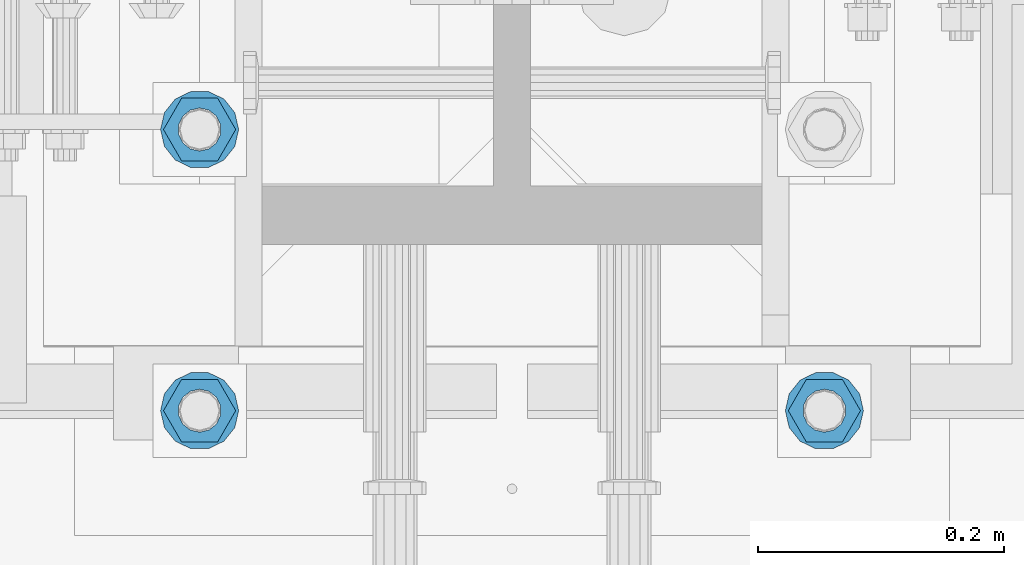
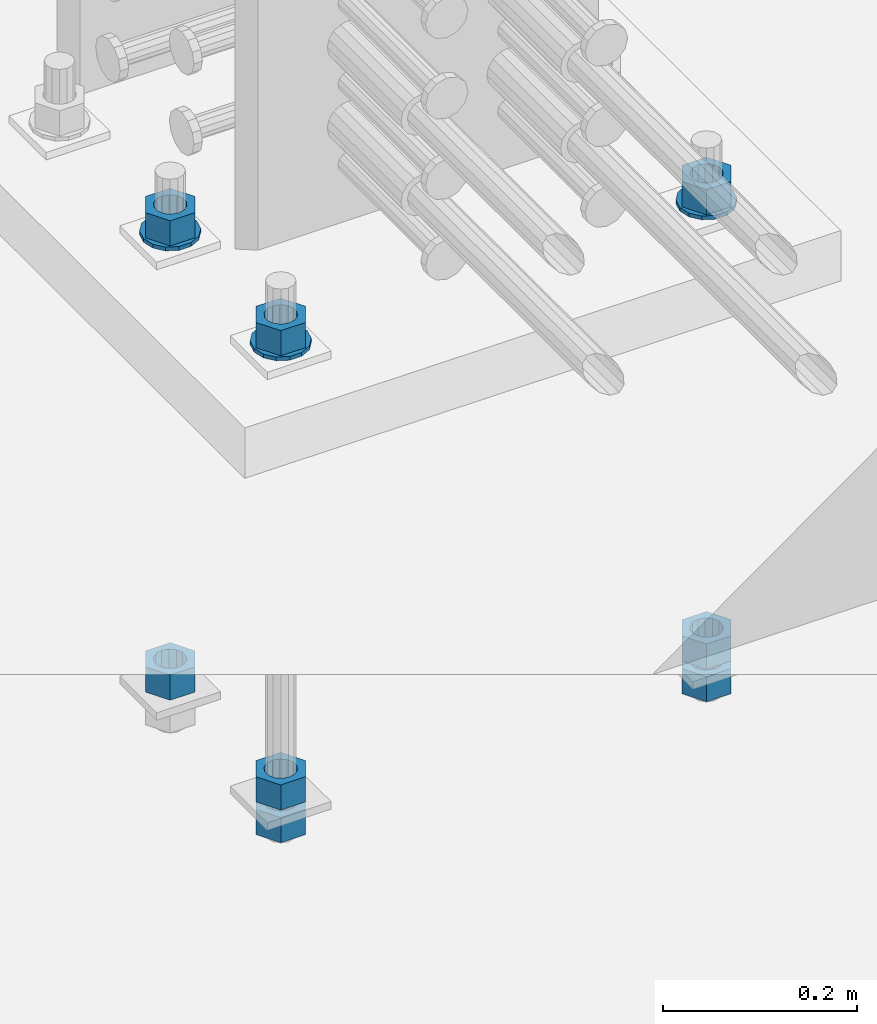
# One storey, part 1007 of 1763: 11 columns, 1 element without a shape of its own.
"""IFC2X3 building model written with IfcOpenShell, lengths in millimetres."""

from ifc_helpers import new_model, si_unit, frame, origin_with_axes, place, context, subcontext, project, spatial, faceted_brep, material, type_object, element, aggregate, save


model = new_model("IFC2X3")

# Units and contexts
model_context = context("Model", 3, precision=1e-05, world=origin_with_axes())
body_context = subcontext(model_context, "Body", "Model", "MODEL_VIEW")
ifc_project = project(units=[si_unit("LENGTHUNIT", "METRE", prefix="MILLI"), si_unit("AREAUNIT", "SQUARE_METRE"), si_unit("VOLUMEUNIT", "CUBIC_METRE"), si_unit("MASSUNIT", "GRAM", prefix="KILO"), si_unit("TIMEUNIT", "SECOND"), si_unit("PLANEANGLEUNIT", "RADIAN"), si_unit("SOLIDANGLEUNIT", "STERADIAN"), si_unit("THERMODYNAMICTEMPERATUREUNIT", "DEGREE_CELSIUS"), si_unit("LUMINOUSINTENSITYUNIT", "LUMEN")], contexts=[model_context])

# Site, building, storey
site_placement = place(None, origin_with_axes())
site = spatial("IfcSite", under=ifc_project, at=site_placement, CompositionType="ELEMENT")
building_placement = place(site_placement, origin_with_axes())
building = spatial("IfcBuilding", under=site, at=building_placement, Name="Undefined", CompositionType="ELEMENT")
storey_placement = place(building_placement, origin_with_axes())
storey = spatial("IfcBuildingStorey", under=building, at=storey_placement, Name="Undefined", CompositionType="ELEMENT", Elevation=0.0)

# Assembly, columns
assembly_placement = place(storey_placement, origin_with_axes())
assembly = element("IfcElementAssembly", 1, at=assembly_placement, inside=storey, Name="TEMPLATE", AssemblyPlace="NOTDEFINED", PredefinedType="RIGID_FRAME")
ifc_material_1 = material(Name="STEEL/A563")
column_type_1 = type_object("IfcColumnType", Name="1-1/4_HEAVY_HEX_NUT", PredefinedType="NOTDEFINED")
column_1_placement = place(assembly_placement, frame((-24281.8372736984, -14058.9000000001, 3957.6375), z_axis=(0.0, -1.0, 0.0), x_axis=(0.0, 0.0, -1.0)))
column_1 = element("IfcColumn", 2, at=column_1_placement, type_object=column_type_1, material=ifc_material_1, Name="NUT", ObjectType="1-1/4_HEAVY_HEX_NUT", context=body_context, shape_type="Brep", body=[
    faceted_brep([(0.0, -29.3700008392334, 0.0), (0.0, -14.6800003051758, -25.4300003051758), (31.75, -14.6800003051758, -25.4300003051758), (31.75, -29.3700008392334, 0.0), (0.0, 14.6800003051758, -25.4300003051758), (31.75, 14.6800003051758, -25.4300003051758), (0.0, 29.3700008392334, 0.0), (31.75, 29.3700008392334, 0.0), (0.0, 14.6800003051758, 25.4300003051758), (31.75, 14.6800003051758, 25.4300003051758), (0.0, -14.6800003051758, 25.4300003051758), (31.75, -14.6800003051758, 25.4300003051758), (0.0, 0.0, 17.4599990844727), (0.0, 7.57560968776022, 15.730915608714), (31.75, 7.57560968775942, 15.7309156087145), (31.75, 0.0, 17.4599990844727), (0.0, 13.6507769681037, 10.8861313696252), (31.75, 13.6507769681048, 10.8861313696314), (0.0, 17.0222404541215, 3.88521530314756), (31.75, 17.02224045412, 3.88521530315316), (0.0, 17.0222404541215, -3.88521530314756), (31.75, 17.02224045412, -3.88521530315332), (0.0, 13.6507769681037, -10.8861313696252), (31.75, 13.6507769681048, -10.8861313696316), (0.0, 7.57560968776022, -15.730915608714), (31.75, 7.57560968775942, -15.7309156087146), (0.0, 0.0, -17.4599990844727), (31.75, 0.0, -17.4599990844727), (0.0, -7.57560968776022, -15.730915608714), (31.75, -7.57560968775942, -15.7309156087145), (0.0, -13.6507769681037, -10.8861313696252), (31.75, -13.6507769681048, -10.8861313696314), (0.0, -17.0222404541215, -3.88521530314756), (31.75, -17.02224045412, -3.88521530315316), (0.0, -17.0222404541215, 3.88521530314756), (31.75, -17.02224045412, 3.88521530315332), (0.0, -13.6507769681037, 10.8861313696252), (31.75, -13.6507769681048, 10.8861313696316), (0.0, -7.57560968776022, 15.730915608714), (31.75, -7.57560968775942, 15.7309156087146)], [[[0, 1, 2, 3]], [[1, 4, 5, 2]], [[4, 6, 7, 5]], [[6, 8, 9, 7]], [[8, 10, 11, 9]], [[10, 0, 3, 11]], [[12, 13, 14, 15]], [[13, 16, 17, 14]], [[16, 18, 19, 17]], [[18, 20, 21, 19]], [[20, 22, 23, 21]], [[22, 24, 25, 23]], [[24, 26, 27, 25]], [[26, 28, 29, 27]], [[28, 30, 31, 29]], [[30, 32, 33, 31]], [[32, 34, 35, 33]], [[34, 36, 37, 35]], [[36, 38, 39, 37]], [[38, 12, 15, 39]], [[5, 7, 9, 11, 3, 2], [17, 19, 21, 23, 25, 27, 29, 31, 33, 35, 37, 39, 15, 14]], [[10, 8, 6, 4, 1, 0], [38, 36, 34, 32, 30, 28, 26, 24, 22, 20, 18, 16, 13, 12]]]),
])
column_2_placement = place(assembly_placement, frame((-24281.8372736984, -14058.9000000001, 3384.55), z_axis=(0.0, -1.0, 0.0), x_axis=(0.0, 0.0, -1.0)))
column_2 = element("IfcColumn", 3, at=column_2_placement, type_object=column_type_1, material=ifc_material_1, Name="NUT", ObjectType="1-1/4_HEAVY_HEX_NUT", context=body_context, shape_type="Brep", body=[
    faceted_brep([(0.0, -29.3700008392334, 0.0), (0.0, -14.6800003051758, -25.4300003051758), (31.75, -14.6800003051758, -25.4300003051758), (31.75, -29.3700008392334, 0.0), (0.0, 14.6800003051758, -25.4300003051758), (31.75, 14.6800003051758, -25.4300003051758), (0.0, 29.3700008392334, 0.0), (31.75, 29.3700008392334, 0.0), (0.0, 14.6800003051758, 25.4300003051758), (31.75, 14.6800003051758, 25.4300003051758), (0.0, -14.6800003051758, 25.4300003051758), (31.75, -14.6800003051758, 25.4300003051758), (0.0, 0.0, 17.4599990844727), (0.0, 7.57560968776022, 15.730915608714), (31.75, 7.57560968775942, 15.7309156087145), (31.75, 0.0, 17.4599990844727), (0.0, 13.6507769681037, 10.8861313696252), (31.75, 13.6507769681048, 10.8861313696314), (0.0, 17.0222404541215, 3.88521530314756), (31.75, 17.02224045412, 3.88521530315316), (0.0, 17.0222404541215, -3.88521530314756), (31.75, 17.02224045412, -3.88521530315332), (0.0, 13.6507769681037, -10.8861313696252), (31.75, 13.6507769681048, -10.8861313696316), (0.0, 7.57560968776022, -15.730915608714), (31.75, 7.57560968775942, -15.7309156087146), (0.0, 0.0, -17.4599990844727), (31.75, 0.0, -17.4599990844727), (0.0, -7.57560968776022, -15.730915608714), (31.75, -7.57560968775942, -15.7309156087145), (0.0, -13.6507769681037, -10.8861313696252), (31.75, -13.6507769681048, -10.8861313696314), (0.0, -17.0222404541215, -3.88521530314756), (31.75, -17.02224045412, -3.88521530315316), (0.0, -17.0222404541215, 3.88521530314756), (31.75, -17.02224045412, 3.88521530315332), (0.0, -13.6507769681037, 10.8861313696252), (31.75, -13.6507769681048, 10.8861313696316), (0.0, -7.57560968776022, 15.730915608714), (31.75, -7.57560968775942, 15.7309156087146)], [[[0, 1, 2, 3]], [[1, 4, 5, 2]], [[4, 6, 7, 5]], [[6, 8, 9, 7]], [[8, 10, 11, 9]], [[10, 0, 3, 11]], [[12, 13, 14, 15]], [[13, 16, 17, 14]], [[16, 18, 19, 17]], [[18, 20, 21, 19]], [[20, 22, 23, 21]], [[22, 24, 25, 23]], [[24, 26, 27, 25]], [[26, 28, 29, 27]], [[28, 30, 31, 29]], [[30, 32, 33, 31]], [[32, 34, 35, 33]], [[34, 36, 37, 35]], [[36, 38, 39, 37]], [[38, 12, 15, 39]], [[5, 7, 9, 11, 3, 2], [17, 19, 21, 23, 25, 27, 29, 31, 33, 35, 37, 39, 15, 14]], [[10, 8, 6, 4, 1, 0], [38, 36, 34, 32, 30, 28, 26, 24, 22, 20, 18, 16, 13, 12]]]),
])
column_3_placement = place(assembly_placement, frame((-24281.8372736984, -14058.9000000001, 3343.275), z_axis=(0.0, -1.0, 0.0), x_axis=(0.0, 0.0, -1.0)))
column_3 = element("IfcColumn", 4, at=column_3_placement, type_object=column_type_1, material=ifc_material_1, Name="NUT", ObjectType="1-1/4_HEAVY_HEX_NUT", context=body_context, shape_type="Brep", body=[
    faceted_brep([(0.0, -29.3700008392334, 0.0), (0.0, -14.6800003051758, -25.4300003051758), (31.75, -14.6800003051758, -25.4300003051758), (31.75, -29.3700008392334, 0.0), (0.0, 14.6800003051758, -25.4300003051758), (31.75, 14.6800003051758, -25.4300003051758), (0.0, 29.3700008392334, 0.0), (31.75, 29.3700008392334, 0.0), (0.0, 14.6800003051758, 25.4300003051758), (31.75, 14.6800003051758, 25.4300003051758), (0.0, -14.6800003051758, 25.4300003051758), (31.75, -14.6800003051758, 25.4300003051758), (0.0, 0.0, 17.4599990844727), (0.0, 7.57560968776022, 15.730915608714), (31.75, 7.57560968775942, 15.7309156087145), (31.75, 0.0, 17.4599990844727), (0.0, 13.6507769681037, 10.8861313696252), (31.75, 13.6507769681048, 10.8861313696314), (0.0, 17.0222404541215, 3.88521530314756), (31.75, 17.02224045412, 3.88521530315316), (0.0, 17.0222404541215, -3.88521530314756), (31.75, 17.02224045412, -3.88521530315332), (0.0, 13.6507769681037, -10.8861313696252), (31.75, 13.6507769681048, -10.8861313696316), (0.0, 7.57560968776022, -15.730915608714), (31.75, 7.57560968775942, -15.7309156087146), (0.0, 0.0, -17.4599990844727), (31.75, 0.0, -17.4599990844727), (0.0, -7.57560968776022, -15.730915608714), (31.75, -7.57560968775942, -15.7309156087145), (0.0, -13.6507769681037, -10.8861313696252), (31.75, -13.6507769681048, -10.8861313696314), (0.0, -17.0222404541215, -3.88521530314756), (31.75, -17.02224045412, -3.88521530315316), (0.0, -17.0222404541215, 3.88521530314756), (31.75, -17.02224045412, 3.88521530315332), (0.0, -13.6507769681037, 10.8861313696252), (31.75, -13.6507769681048, 10.8861313696316), (0.0, -7.57560968776022, 15.730915608714), (31.75, -7.57560968775942, 15.7309156087146)], [[[0, 1, 2, 3]], [[1, 4, 5, 2]], [[4, 6, 7, 5]], [[6, 8, 9, 7]], [[8, 10, 11, 9]], [[10, 0, 3, 11]], [[12, 13, 14, 15]], [[13, 16, 17, 14]], [[16, 18, 19, 17]], [[18, 20, 21, 19]], [[20, 22, 23, 21]], [[22, 24, 25, 23]], [[24, 26, 27, 25]], [[26, 28, 29, 27]], [[28, 30, 31, 29]], [[30, 32, 33, 31]], [[32, 34, 35, 33]], [[34, 36, 37, 35]], [[36, 38, 39, 37]], [[38, 12, 15, 39]], [[5, 7, 9, 11, 3, 2], [17, 19, 21, 23, 25, 27, 29, 31, 33, 35, 37, 39, 15, 14]], [[10, 8, 6, 4, 1, 0], [38, 36, 34, 32, 30, 28, 26, 24, 22, 20, 18, 16, 13, 12]]]),
])
column_4_placement = place(assembly_placement, frame((-23773.8372736984, -14058.9000000001, 3957.6375), z_axis=(0.0, 1.0, 0.0), x_axis=(0.0, 0.0, -1.0)))
column_4 = element("IfcColumn", 5, at=column_4_placement, type_object=column_type_1, material=ifc_material_1, Name="NUT", ObjectType="1-1/4_HEAVY_HEX_NUT", context=body_context, shape_type="Brep", body=[
    faceted_brep([(0.0, -29.3700008392334, 0.0), (0.0, -14.6800003051758, -25.4300003051758), (31.75, -14.6800003051758, -25.4300003051758), (31.75, -29.3700008392334, 0.0), (0.0, 14.6800003051758, -25.4300003051758), (31.75, 14.6800003051758, -25.4300003051758), (0.0, 29.3700008392334, 0.0), (31.75, 29.3700008392334, 0.0), (0.0, 14.6800003051758, 25.4300003051758), (31.75, 14.6800003051758, 25.4300003051758), (0.0, -14.6800003051758, 25.4300003051758), (31.75, -14.6800003051758, 25.4300003051758), (0.0, 0.0, 17.4599990844727), (0.0, 7.57560968776022, 15.730915608714), (31.75, 7.57560968775942, 15.7309156087145), (31.75, 0.0, 17.4599990844727), (0.0, 13.6507769681037, 10.8861313696252), (31.75, 13.6507769681048, 10.8861313696314), (0.0, 17.0222404541215, 3.88521530314756), (31.75, 17.02224045412, 3.88521530315316), (0.0, 17.0222404541215, -3.88521530314756), (31.75, 17.02224045412, -3.88521530315332), (0.0, 13.6507769681037, -10.8861313696252), (31.75, 13.6507769681048, -10.8861313696316), (0.0, 7.57560968776022, -15.730915608714), (31.75, 7.57560968775942, -15.7309156087146), (0.0, 0.0, -17.4599990844727), (31.75, 0.0, -17.4599990844727), (0.0, -7.57560968776022, -15.730915608714), (31.75, -7.57560968775942, -15.7309156087145), (0.0, -13.6507769681037, -10.8861313696252), (31.75, -13.6507769681048, -10.8861313696314), (0.0, -17.0222404541215, -3.88521530314756), (31.75, -17.02224045412, -3.88521530315316), (0.0, -17.0222404541215, 3.88521530314756), (31.75, -17.02224045412, 3.88521530315332), (0.0, -13.6507769681037, 10.8861313696252), (31.75, -13.6507769681048, 10.8861313696316), (0.0, -7.57560968776022, 15.730915608714), (31.75, -7.57560968775942, 15.7309156087146)], [[[0, 1, 2, 3]], [[1, 4, 5, 2]], [[4, 6, 7, 5]], [[6, 8, 9, 7]], [[8, 10, 11, 9]], [[10, 0, 3, 11]], [[12, 13, 14, 15]], [[13, 16, 17, 14]], [[16, 18, 19, 17]], [[18, 20, 21, 19]], [[20, 22, 23, 21]], [[22, 24, 25, 23]], [[24, 26, 27, 25]], [[26, 28, 29, 27]], [[28, 30, 31, 29]], [[30, 32, 33, 31]], [[32, 34, 35, 33]], [[34, 36, 37, 35]], [[36, 38, 39, 37]], [[38, 12, 15, 39]], [[5, 7, 9, 11, 3, 2], [17, 19, 21, 23, 25, 27, 29, 31, 33, 35, 37, 39, 15, 14]], [[10, 8, 6, 4, 1, 0], [38, 36, 34, 32, 30, 28, 26, 24, 22, 20, 18, 16, 13, 12]]]),
])
column_5_placement = place(assembly_placement, frame((-23773.8372736984, -14058.9000000001, 3384.55), z_axis=(0.0, 1.0, 0.0), x_axis=(0.0, 0.0, -1.0)))
column_5 = element("IfcColumn", 6, at=column_5_placement, type_object=column_type_1, material=ifc_material_1, Name="NUT", ObjectType="1-1/4_HEAVY_HEX_NUT", context=body_context, shape_type="Brep", body=[
    faceted_brep([(0.0, -29.3700008392334, 0.0), (0.0, -14.6800003051758, -25.4300003051758), (31.75, -14.6800003051758, -25.4300003051758), (31.75, -29.3700008392334, 0.0), (0.0, 14.6800003051758, -25.4300003051758), (31.75, 14.6800003051758, -25.4300003051758), (0.0, 29.3700008392334, 0.0), (31.75, 29.3700008392334, 0.0), (0.0, 14.6800003051758, 25.4300003051758), (31.75, 14.6800003051758, 25.4300003051758), (0.0, -14.6800003051758, 25.4300003051758), (31.75, -14.6800003051758, 25.4300003051758), (0.0, 0.0, 17.4599990844727), (0.0, 7.57560968776022, 15.730915608714), (31.75, 7.57560968775942, 15.7309156087145), (31.75, 0.0, 17.4599990844727), (0.0, 13.6507769681037, 10.8861313696252), (31.75, 13.6507769681048, 10.8861313696314), (0.0, 17.0222404541215, 3.88521530314756), (31.75, 17.02224045412, 3.88521530315316), (0.0, 17.0222404541215, -3.88521530314756), (31.75, 17.02224045412, -3.88521530315332), (0.0, 13.6507769681037, -10.8861313696252), (31.75, 13.6507769681048, -10.8861313696316), (0.0, 7.57560968776022, -15.730915608714), (31.75, 7.57560968775942, -15.7309156087146), (0.0, 0.0, -17.4599990844727), (31.75, 0.0, -17.4599990844727), (0.0, -7.57560968776022, -15.730915608714), (31.75, -7.57560968775942, -15.7309156087145), (0.0, -13.6507769681037, -10.8861313696252), (31.75, -13.6507769681048, -10.8861313696314), (0.0, -17.0222404541215, -3.88521530314756), (31.75, -17.02224045412, -3.88521530315316), (0.0, -17.0222404541215, 3.88521530314756), (31.75, -17.02224045412, 3.88521530315332), (0.0, -13.6507769681037, 10.8861313696252), (31.75, -13.6507769681048, 10.8861313696316), (0.0, -7.57560968776022, 15.730915608714), (31.75, -7.57560968775942, 15.7309156087146)], [[[0, 1, 2, 3]], [[1, 4, 5, 2]], [[4, 6, 7, 5]], [[6, 8, 9, 7]], [[8, 10, 11, 9]], [[10, 0, 3, 11]], [[12, 13, 14, 15]], [[13, 16, 17, 14]], [[16, 18, 19, 17]], [[18, 20, 21, 19]], [[20, 22, 23, 21]], [[22, 24, 25, 23]], [[24, 26, 27, 25]], [[26, 28, 29, 27]], [[28, 30, 31, 29]], [[30, 32, 33, 31]], [[32, 34, 35, 33]], [[34, 36, 37, 35]], [[36, 38, 39, 37]], [[38, 12, 15, 39]], [[5, 7, 9, 11, 3, 2], [17, 19, 21, 23, 25, 27, 29, 31, 33, 35, 37, 39, 15, 14]], [[10, 8, 6, 4, 1, 0], [38, 36, 34, 32, 30, 28, 26, 24, 22, 20, 18, 16, 13, 12]]]),
])
column_6_placement = place(assembly_placement, frame((-23773.8372736984, -14058.9000000001, 3343.275), z_axis=(0.0, 1.0, 0.0), x_axis=(0.0, 0.0, -1.0)))
column_6 = element("IfcColumn", 7, at=column_6_placement, type_object=column_type_1, material=ifc_material_1, Name="NUT", ObjectType="1-1/4_HEAVY_HEX_NUT", context=body_context, shape_type="Brep", body=[
    faceted_brep([(0.0, -29.3700008392334, 0.0), (0.0, -14.6800003051758, -25.4300003051758), (31.75, -14.6800003051758, -25.4300003051758), (31.75, -29.3700008392334, 0.0), (0.0, 14.6800003051758, -25.4300003051758), (31.75, 14.6800003051758, -25.4300003051758), (0.0, 29.3700008392334, 0.0), (31.75, 29.3700008392334, 0.0), (0.0, 14.6800003051758, 25.4300003051758), (31.75, 14.6800003051758, 25.4300003051758), (0.0, -14.6800003051758, 25.4300003051758), (31.75, -14.6800003051758, 25.4300003051758), (0.0, 0.0, 17.4599990844727), (0.0, 7.57560968776022, 15.730915608714), (31.75, 7.57560968775942, 15.7309156087145), (31.75, 0.0, 17.4599990844727), (0.0, 13.6507769681037, 10.8861313696252), (31.75, 13.6507769681048, 10.8861313696314), (0.0, 17.0222404541215, 3.88521530314756), (31.75, 17.02224045412, 3.88521530315316), (0.0, 17.0222404541215, -3.88521530314756), (31.75, 17.02224045412, -3.88521530315332), (0.0, 13.6507769681037, -10.8861313696252), (31.75, 13.6507769681048, -10.8861313696316), (0.0, 7.57560968776022, -15.730915608714), (31.75, 7.57560968775942, -15.7309156087146), (0.0, 0.0, -17.4599990844727), (31.75, 0.0, -17.4599990844727), (0.0, -7.57560968776022, -15.730915608714), (31.75, -7.57560968775942, -15.7309156087145), (0.0, -13.6507769681037, -10.8861313696252), (31.75, -13.6507769681048, -10.8861313696314), (0.0, -17.0222404541215, -3.88521530314756), (31.75, -17.02224045412, -3.88521530315316), (0.0, -17.0222404541215, 3.88521530314756), (31.75, -17.02224045412, 3.88521530315332), (0.0, -13.6507769681037, 10.8861313696252), (31.75, -13.6507769681048, 10.8861313696316), (0.0, -7.57560968776022, 15.730915608714), (31.75, -7.57560968775942, 15.7309156087146)], [[[0, 1, 2, 3]], [[1, 4, 5, 2]], [[4, 6, 7, 5]], [[6, 8, 9, 7]], [[8, 10, 11, 9]], [[10, 0, 3, 11]], [[12, 13, 14, 15]], [[13, 16, 17, 14]], [[16, 18, 19, 17]], [[18, 20, 21, 19]], [[20, 22, 23, 21]], [[22, 24, 25, 23]], [[24, 26, 27, 25]], [[26, 28, 29, 27]], [[28, 30, 31, 29]], [[30, 32, 33, 31]], [[32, 34, 35, 33]], [[34, 36, 37, 35]], [[36, 38, 39, 37]], [[38, 12, 15, 39]], [[5, 7, 9, 11, 3, 2], [17, 19, 21, 23, 25, 27, 29, 31, 33, 35, 37, 39, 15, 14]], [[10, 8, 6, 4, 1, 0], [38, 36, 34, 32, 30, 28, 26, 24, 22, 20, 18, 16, 13, 12]]]),
])
column_7_placement = place(assembly_placement, frame((-24281.8372736984, -13830.3000000001, 3957.6375), z_axis=(0.0, -1.0, 0.0), x_axis=(0.0, 0.0, -1.0)))
column_7 = element("IfcColumn", 8, at=column_7_placement, type_object=column_type_1, material=ifc_material_1, Name="NUT", ObjectType="1-1/4_HEAVY_HEX_NUT", context=body_context, shape_type="Brep", body=[
    faceted_brep([(0.0, -29.3700008392334, 0.0), (0.0, -14.6800003051758, -25.4300003051758), (31.75, -14.6800003051758, -25.4300003051758), (31.75, -29.3700008392334, 0.0), (0.0, 14.6800003051758, -25.4300003051758), (31.75, 14.6800003051758, -25.4300003051758), (0.0, 29.3700008392334, 0.0), (31.75, 29.3700008392334, 0.0), (0.0, 14.6800003051758, 25.4300003051758), (31.75, 14.6800003051758, 25.4300003051758), (0.0, -14.6800003051758, 25.4300003051758), (31.75, -14.6800003051758, 25.4300003051758), (0.0, 0.0, 17.4599990844727), (0.0, 7.57560968776022, 15.730915608714), (31.75, 7.57560968775942, 15.7309156087145), (31.75, 0.0, 17.4599990844727), (0.0, 13.6507769681037, 10.8861313696252), (31.75, 13.6507769681048, 10.8861313696314), (0.0, 17.0222404541215, 3.88521530314756), (31.75, 17.02224045412, 3.88521530315316), (0.0, 17.0222404541215, -3.88521530314756), (31.75, 17.02224045412, -3.88521530315332), (0.0, 13.6507769681037, -10.8861313696252), (31.75, 13.6507769681048, -10.8861313696316), (0.0, 7.57560968776022, -15.730915608714), (31.75, 7.57560968775942, -15.7309156087146), (0.0, 0.0, -17.4599990844727), (31.75, 0.0, -17.4599990844727), (0.0, -7.57560968776022, -15.730915608714), (31.75, -7.57560968775942, -15.7309156087145), (0.0, -13.6507769681037, -10.8861313696252), (31.75, -13.6507769681048, -10.8861313696314), (0.0, -17.0222404541215, -3.88521530314756), (31.75, -17.02224045412, -3.88521530315316), (0.0, -17.0222404541215, 3.88521530314756), (31.75, -17.02224045412, 3.88521530315332), (0.0, -13.6507769681037, 10.8861313696252), (31.75, -13.6507769681048, 10.8861313696316), (0.0, -7.57560968776022, 15.730915608714), (31.75, -7.57560968775942, 15.7309156087146)], [[[0, 1, 2, 3]], [[1, 4, 5, 2]], [[4, 6, 7, 5]], [[6, 8, 9, 7]], [[8, 10, 11, 9]], [[10, 0, 3, 11]], [[12, 13, 14, 15]], [[13, 16, 17, 14]], [[16, 18, 19, 17]], [[18, 20, 21, 19]], [[20, 22, 23, 21]], [[22, 24, 25, 23]], [[24, 26, 27, 25]], [[26, 28, 29, 27]], [[28, 30, 31, 29]], [[30, 32, 33, 31]], [[32, 34, 35, 33]], [[34, 36, 37, 35]], [[36, 38, 39, 37]], [[38, 12, 15, 39]], [[5, 7, 9, 11, 3, 2], [17, 19, 21, 23, 25, 27, 29, 31, 33, 35, 37, 39, 15, 14]], [[10, 8, 6, 4, 1, 0], [38, 36, 34, 32, 30, 28, 26, 24, 22, 20, 18, 16, 13, 12]]]),
])
column_8_placement = place(assembly_placement, frame((-24281.8372736984, -13830.3000000001, 3384.55), z_axis=(0.0, -1.0, 0.0), x_axis=(0.0, 0.0, -1.0)))
column_8 = element("IfcColumn", 9, at=column_8_placement, type_object=column_type_1, material=ifc_material_1, Name="NUT", ObjectType="1-1/4_HEAVY_HEX_NUT", context=body_context, shape_type="Brep", body=[
    faceted_brep([(0.0, -29.3700008392334, 0.0), (0.0, -14.6800003051758, -25.4300003051758), (31.75, -14.6800003051758, -25.4300003051758), (31.75, -29.3700008392334, 0.0), (0.0, 14.6800003051758, -25.4300003051758), (31.75, 14.6800003051758, -25.4300003051758), (0.0, 29.3700008392334, 0.0), (31.75, 29.3700008392334, 0.0), (0.0, 14.6800003051758, 25.4300003051758), (31.75, 14.6800003051758, 25.4300003051758), (0.0, -14.6800003051758, 25.4300003051758), (31.75, -14.6800003051758, 25.4300003051758), (0.0, 0.0, 17.4599990844727), (0.0, 7.57560968776022, 15.730915608714), (31.75, 7.57560968775942, 15.7309156087145), (31.75, 0.0, 17.4599990844727), (0.0, 13.6507769681037, 10.8861313696252), (31.75, 13.6507769681048, 10.8861313696314), (0.0, 17.0222404541215, 3.88521530314756), (31.75, 17.02224045412, 3.88521530315316), (0.0, 17.0222404541215, -3.88521530314756), (31.75, 17.02224045412, -3.88521530315332), (0.0, 13.6507769681037, -10.8861313696252), (31.75, 13.6507769681048, -10.8861313696316), (0.0, 7.57560968776022, -15.730915608714), (31.75, 7.57560968775942, -15.7309156087146), (0.0, 0.0, -17.4599990844727), (31.75, 0.0, -17.4599990844727), (0.0, -7.57560968776022, -15.730915608714), (31.75, -7.57560968775942, -15.7309156087145), (0.0, -13.6507769681037, -10.8861313696252), (31.75, -13.6507769681048, -10.8861313696314), (0.0, -17.0222404541215, -3.88521530314756), (31.75, -17.02224045412, -3.88521530315316), (0.0, -17.0222404541215, 3.88521530314756), (31.75, -17.02224045412, 3.88521530315332), (0.0, -13.6507769681037, 10.8861313696252), (31.75, -13.6507769681048, 10.8861313696316), (0.0, -7.57560968776022, 15.730915608714), (31.75, -7.57560968775942, 15.7309156087146)], [[[0, 1, 2, 3]], [[1, 4, 5, 2]], [[4, 6, 7, 5]], [[6, 8, 9, 7]], [[8, 10, 11, 9]], [[10, 0, 3, 11]], [[12, 13, 14, 15]], [[13, 16, 17, 14]], [[16, 18, 19, 17]], [[18, 20, 21, 19]], [[20, 22, 23, 21]], [[22, 24, 25, 23]], [[24, 26, 27, 25]], [[26, 28, 29, 27]], [[28, 30, 31, 29]], [[30, 32, 33, 31]], [[32, 34, 35, 33]], [[34, 36, 37, 35]], [[36, 38, 39, 37]], [[38, 12, 15, 39]], [[5, 7, 9, 11, 3, 2], [17, 19, 21, 23, 25, 27, 29, 31, 33, 35, 37, 39, 15, 14]], [[10, 8, 6, 4, 1, 0], [38, 36, 34, 32, 30, 28, 26, 24, 22, 20, 18, 16, 13, 12]]]),
])
ifc_material_2 = material(Name="STEEL/F436")
column_type_2 = type_object("IfcColumnType", Name="1-1/4_WASHER", PredefinedType="NOTDEFINED")
column_9_placement = place(assembly_placement, frame((-24281.8372736984, -14058.9000000001, 3925.8875), z_axis=(0.0, -1.0, 0.0), x_axis=(0.0, 0.0, -1.0)))
column_9 = element("IfcColumn", 10, at=column_9_placement, type_object=column_type_2, material=ifc_material_2, Name="WASHER", ObjectType="1-1/4_WASHER", context=body_context, shape_type="Brep", body=[
    faceted_brep([(-4.54747350886464e-13, -31.7499999999964, 0.0), (0.0, -28.6057615559002, -13.7758087169827), (4.76249999999982, -28.6057615559002, -13.7758087169827), (4.76249999999982, -31.75, 0.0), (0.0, -19.795801209013, -24.8231495683602), (4.76249999999982, -19.795801209013, -24.8231495683602), (0.0, -7.06503965311276, -30.9539612117732), (4.76249999999982, -7.06503965311276, -30.9539612117732), (0.0, 7.06503965311276, -30.9539612117732), (4.76249999999982, 7.06503965311276, -30.9539612117732), (0.0, 19.7958012090166, -24.8231495683602), (4.76249999999982, 19.7958012090166, -24.8231495683602), (0.0, 28.6057615559039, -13.7758087169827), (4.76249999999982, 28.6057615559039, -13.7758087169827), (-5.91171556152403e-12, 31.7499999999891, 0.0), (4.76249999999982, 31.75, 0.0), (0.0, 28.6057615559002, 13.7758087169827), (4.76249999999982, 28.6057615559002, 13.7758087169827), (0.0, 19.795801209013, 24.8231495683602), (4.76249999999982, 19.795801209013, 24.8231495683602), (0.0, 7.06503965311276, 30.9539612117731), (4.76249999999982, 7.06503965311276, 30.9539612117731), (0.0, -7.06503965311276, 30.9539612117731), (4.76249999999982, -7.06503965311276, 30.9539612117731), (0.0, -19.7958012090166, 24.8231495683602), (4.76249999999982, -19.7958012090166, 24.8231495683602), (0.0, -28.6057615559039, 13.7758087169827), (4.76249999999982, -28.6057615559039, 13.7758087169827), (0.0, 0.0, 17.4599990844727), (0.0, 7.57560968776022, 15.730915608714), (4.76249999999982, 7.57560968775942, 15.7309156087145), (4.76249999999982, 0.0, 17.4599990844727), (0.0, 13.6507769681037, 10.8861313696252), (4.76249999999982, 13.6507769681048, 10.8861313696314), (0.0, 17.0222404541215, 3.88521530314756), (4.76249999999982, 17.02224045412, 3.88521530315316), (0.0, 17.0222404541215, -3.88521530314756), (4.76249999999982, 17.02224045412, -3.88521530315332), (0.0, 13.6507769681037, -10.8861313696252), (4.76249999999982, 13.6507769681048, -10.8861313696316), (0.0, 7.57560968776022, -15.730915608714), (4.76249999999982, 7.57560968775942, -15.7309156087146), (0.0, 0.0, -17.4599990844727), (4.76249999999982, 0.0, -17.4599990844727), (0.0, -7.57560968776022, -15.730915608714), (4.76249999999982, -7.57560968775942, -15.7309156087145), (0.0, -13.6507769681037, -10.8861313696252), (4.76249999999982, -13.6507769681048, -10.8861313696314), (0.0, -17.0222404541215, -3.88521530314756), (4.76249999999982, -17.02224045412, -3.88521530315316), (0.0, -17.0222404541215, 3.88521530314756), (4.76249999999982, -17.02224045412, 3.88521530315332), (0.0, -13.6507769681037, 10.8861313696252), (4.76249999999982, -13.6507769681048, 10.8861313696316), (0.0, -7.57560968776022, 15.730915608714), (4.76249999999982, -7.57560968775942, 15.7309156087146)], [[[0, 1, 2, 3]], [[1, 4, 5, 2]], [[4, 6, 7, 5]], [[6, 8, 9, 7]], [[8, 10, 11, 9]], [[10, 12, 13, 11]], [[12, 14, 15, 13]], [[14, 16, 17, 15]], [[16, 18, 19, 17]], [[18, 20, 21, 19]], [[20, 22, 23, 21]], [[22, 24, 25, 23]], [[24, 26, 27, 25]], [[26, 0, 3, 27]], [[28, 29, 30, 31]], [[29, 32, 33, 30]], [[32, 34, 35, 33]], [[34, 36, 37, 35]], [[36, 38, 39, 37]], [[38, 40, 41, 39]], [[40, 42, 43, 41]], [[42, 44, 45, 43]], [[44, 46, 47, 45]], [[46, 48, 49, 47]], [[48, 50, 51, 49]], [[50, 52, 53, 51]], [[52, 54, 55, 53]], [[54, 28, 31, 55]], [[5, 7, 9, 11, 13, 15, 17, 19, 21, 23, 25, 27, 3, 2], [33, 35, 37, 39, 41, 43, 45, 47, 49, 51, 53, 55, 31, 30]], [[26, 24, 22, 20, 18, 16, 14, 12, 10, 8, 6, 4, 1, 0], [54, 52, 50, 48, 46, 44, 42, 40, 38, 36, 34, 32, 29, 28]]]),
])
column_10_placement = place(assembly_placement, frame((-23773.8372736984, -14058.9000000001, 3925.8875), z_axis=(0.0, 1.0, 0.0), x_axis=(0.0, 0.0, -1.0)))
column_10 = element("IfcColumn", 11, at=column_10_placement, type_object=column_type_2, material=ifc_material_2, Name="WASHER", ObjectType="1-1/4_WASHER", context=body_context, shape_type="Brep", body=[
    faceted_brep([(-4.54747350886464e-13, -31.7499999999964, 0.0), (0.0, -28.6057615559002, -13.7758087169827), (4.76249999999982, -28.6057615559002, -13.7758087169827), (4.76249999999982, -31.75, 0.0), (0.0, -19.795801209013, -24.8231495683602), (4.76249999999982, -19.795801209013, -24.8231495683602), (0.0, -7.06503965311276, -30.9539612117732), (4.76249999999982, -7.06503965311276, -30.9539612117732), (0.0, 7.06503965311276, -30.9539612117732), (4.76249999999982, 7.06503965311276, -30.9539612117732), (0.0, 19.7958012090166, -24.8231495683602), (4.76249999999982, 19.7958012090166, -24.8231495683602), (0.0, 28.6057615559039, -13.7758087169827), (4.76249999999982, 28.6057615559039, -13.7758087169827), (-5.91171556152403e-12, 31.7499999999891, 0.0), (4.76249999999982, 31.75, 0.0), (0.0, 28.6057615559002, 13.7758087169827), (4.76249999999982, 28.6057615559002, 13.7758087169827), (0.0, 19.795801209013, 24.8231495683602), (4.76249999999982, 19.795801209013, 24.8231495683602), (0.0, 7.06503965311276, 30.9539612117731), (4.76249999999982, 7.06503965311276, 30.9539612117731), (0.0, -7.06503965311276, 30.9539612117731), (4.76249999999982, -7.06503965311276, 30.9539612117731), (0.0, -19.7958012090166, 24.8231495683602), (4.76249999999982, -19.7958012090166, 24.8231495683602), (0.0, -28.6057615559039, 13.7758087169827), (4.76249999999982, -28.6057615559039, 13.7758087169827), (0.0, 0.0, 17.4599990844727), (0.0, 7.57560968776022, 15.730915608714), (4.76249999999982, 7.57560968775942, 15.7309156087145), (4.76249999999982, 0.0, 17.4599990844727), (0.0, 13.6507769681037, 10.8861313696252), (4.76249999999982, 13.6507769681048, 10.8861313696314), (0.0, 17.0222404541215, 3.88521530314756), (4.76249999999982, 17.02224045412, 3.88521530315316), (0.0, 17.0222404541215, -3.88521530314756), (4.76249999999982, 17.02224045412, -3.88521530315332), (0.0, 13.6507769681037, -10.8861313696252), (4.76249999999982, 13.6507769681048, -10.8861313696316), (0.0, 7.57560968776022, -15.730915608714), (4.76249999999982, 7.57560968775942, -15.7309156087146), (0.0, 0.0, -17.4599990844727), (4.76249999999982, 0.0, -17.4599990844727), (0.0, -7.57560968776022, -15.730915608714), (4.76249999999982, -7.57560968775942, -15.7309156087145), (0.0, -13.6507769681037, -10.8861313696252), (4.76249999999982, -13.6507769681048, -10.8861313696314), (0.0, -17.0222404541215, -3.88521530314756), (4.76249999999982, -17.02224045412, -3.88521530315316), (0.0, -17.0222404541215, 3.88521530314756), (4.76249999999982, -17.02224045412, 3.88521530315332), (0.0, -13.6507769681037, 10.8861313696252), (4.76249999999982, -13.6507769681048, 10.8861313696316), (0.0, -7.57560968776022, 15.730915608714), (4.76249999999982, -7.57560968775942, 15.7309156087146)], [[[0, 1, 2, 3]], [[1, 4, 5, 2]], [[4, 6, 7, 5]], [[6, 8, 9, 7]], [[8, 10, 11, 9]], [[10, 12, 13, 11]], [[12, 14, 15, 13]], [[14, 16, 17, 15]], [[16, 18, 19, 17]], [[18, 20, 21, 19]], [[20, 22, 23, 21]], [[22, 24, 25, 23]], [[24, 26, 27, 25]], [[26, 0, 3, 27]], [[28, 29, 30, 31]], [[29, 32, 33, 30]], [[32, 34, 35, 33]], [[34, 36, 37, 35]], [[36, 38, 39, 37]], [[38, 40, 41, 39]], [[40, 42, 43, 41]], [[42, 44, 45, 43]], [[44, 46, 47, 45]], [[46, 48, 49, 47]], [[48, 50, 51, 49]], [[50, 52, 53, 51]], [[52, 54, 55, 53]], [[54, 28, 31, 55]], [[5, 7, 9, 11, 13, 15, 17, 19, 21, 23, 25, 27, 3, 2], [33, 35, 37, 39, 41, 43, 45, 47, 49, 51, 53, 55, 31, 30]], [[26, 24, 22, 20, 18, 16, 14, 12, 10, 8, 6, 4, 1, 0], [54, 52, 50, 48, 46, 44, 42, 40, 38, 36, 34, 32, 29, 28]]]),
])
column_11_placement = place(assembly_placement, frame((-24281.8372736984, -13830.3000000001, 3925.8875), z_axis=(0.0, -1.0, 0.0), x_axis=(0.0, 0.0, -1.0)))
column_11 = element("IfcColumn", 12, at=column_11_placement, type_object=column_type_2, material=ifc_material_2, Name="WASHER", ObjectType="1-1/4_WASHER", context=body_context, shape_type="Brep", body=[
    faceted_brep([(-4.54747350886464e-13, -31.7499999999964, 0.0), (0.0, -28.6057615559002, -13.7758087169827), (4.76249999999982, -28.6057615559002, -13.7758087169827), (4.76249999999982, -31.75, 0.0), (0.0, -19.795801209013, -24.8231495683602), (4.76249999999982, -19.795801209013, -24.8231495683602), (0.0, -7.06503965311276, -30.9539612117732), (4.76249999999982, -7.06503965311276, -30.9539612117732), (0.0, 7.06503965311276, -30.9539612117732), (4.76249999999982, 7.06503965311276, -30.9539612117732), (0.0, 19.7958012090166, -24.8231495683602), (4.76249999999982, 19.7958012090166, -24.8231495683602), (0.0, 28.6057615559039, -13.7758087169827), (4.76249999999982, 28.6057615559039, -13.7758087169827), (-5.91171556152403e-12, 31.7499999999891, 0.0), (4.76249999999982, 31.75, 0.0), (0.0, 28.6057615559002, 13.7758087169827), (4.76249999999982, 28.6057615559002, 13.7758087169827), (0.0, 19.795801209013, 24.8231495683602), (4.76249999999982, 19.795801209013, 24.8231495683602), (0.0, 7.06503965311276, 30.9539612117731), (4.76249999999982, 7.06503965311276, 30.9539612117731), (0.0, -7.06503965311276, 30.9539612117731), (4.76249999999982, -7.06503965311276, 30.9539612117731), (0.0, -19.7958012090166, 24.8231495683602), (4.76249999999982, -19.7958012090166, 24.8231495683602), (0.0, -28.6057615559039, 13.7758087169827), (4.76249999999982, -28.6057615559039, 13.7758087169827), (0.0, 0.0, 17.4599990844727), (0.0, 7.57560968776022, 15.730915608714), (4.76249999999982, 7.57560968775942, 15.7309156087145), (4.76249999999982, 0.0, 17.4599990844727), (0.0, 13.6507769681037, 10.8861313696252), (4.76249999999982, 13.6507769681048, 10.8861313696314), (0.0, 17.0222404541215, 3.88521530314756), (4.76249999999982, 17.02224045412, 3.88521530315316), (0.0, 17.0222404541215, -3.88521530314756), (4.76249999999982, 17.02224045412, -3.88521530315332), (0.0, 13.6507769681037, -10.8861313696252), (4.76249999999982, 13.6507769681048, -10.8861313696316), (0.0, 7.57560968776022, -15.730915608714), (4.76249999999982, 7.57560968775942, -15.7309156087146), (0.0, 0.0, -17.4599990844727), (4.76249999999982, 0.0, -17.4599990844727), (0.0, -7.57560968776022, -15.730915608714), (4.76249999999982, -7.57560968775942, -15.7309156087145), (0.0, -13.6507769681037, -10.8861313696252), (4.76249999999982, -13.6507769681048, -10.8861313696314), (0.0, -17.0222404541215, -3.88521530314756), (4.76249999999982, -17.02224045412, -3.88521530315316), (0.0, -17.0222404541215, 3.88521530314756), (4.76249999999982, -17.02224045412, 3.88521530315332), (0.0, -13.6507769681037, 10.8861313696252), (4.76249999999982, -13.6507769681048, 10.8861313696316), (0.0, -7.57560968776022, 15.730915608714), (4.76249999999982, -7.57560968775942, 15.7309156087146)], [[[0, 1, 2, 3]], [[1, 4, 5, 2]], [[4, 6, 7, 5]], [[6, 8, 9, 7]], [[8, 10, 11, 9]], [[10, 12, 13, 11]], [[12, 14, 15, 13]], [[14, 16, 17, 15]], [[16, 18, 19, 17]], [[18, 20, 21, 19]], [[20, 22, 23, 21]], [[22, 24, 25, 23]], [[24, 26, 27, 25]], [[26, 0, 3, 27]], [[28, 29, 30, 31]], [[29, 32, 33, 30]], [[32, 34, 35, 33]], [[34, 36, 37, 35]], [[36, 38, 39, 37]], [[38, 40, 41, 39]], [[40, 42, 43, 41]], [[42, 44, 45, 43]], [[44, 46, 47, 45]], [[46, 48, 49, 47]], [[48, 50, 51, 49]], [[50, 52, 53, 51]], [[52, 54, 55, 53]], [[54, 28, 31, 55]], [[5, 7, 9, 11, 13, 15, 17, 19, 21, 23, 25, 27, 3, 2], [33, 35, 37, 39, 41, 43, 45, 47, 49, 51, 53, 55, 31, 30]], [[26, 24, 22, 20, 18, 16, 14, 12, 10, 8, 6, 4, 1, 0], [54, 52, 50, 48, 46, 44, 42, 40, 38, 36, 34, 32, 29, 28]]]),
])
aggregate(assembly, [column_1, column_9, column_2, column_3, column_4, column_10, column_5, column_6, column_7, column_11, column_8])

save(model, "model.ifc")
